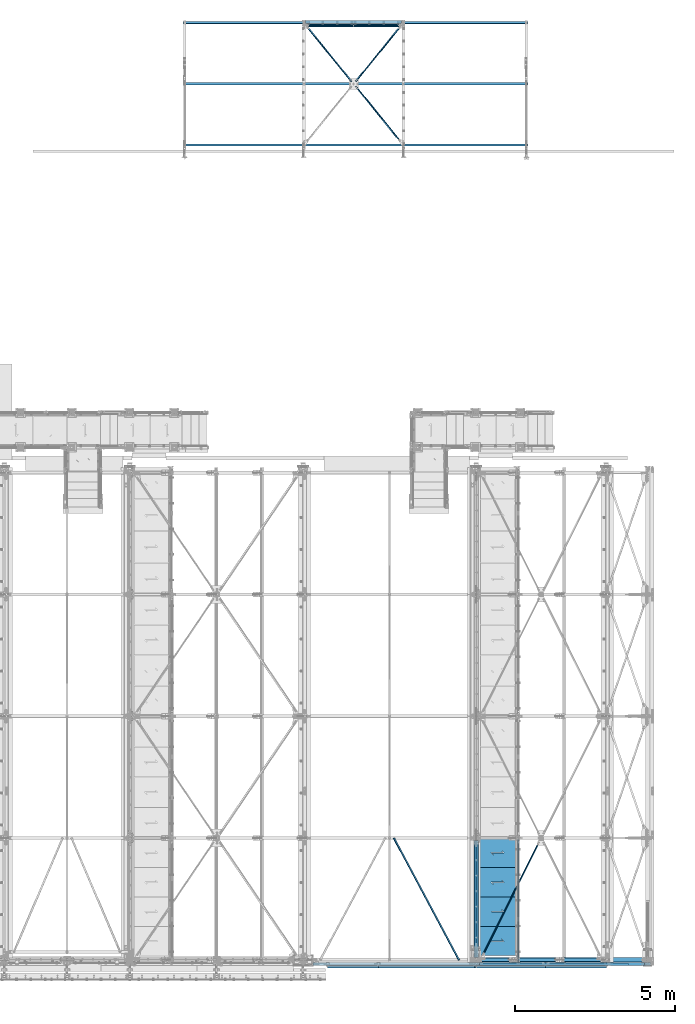
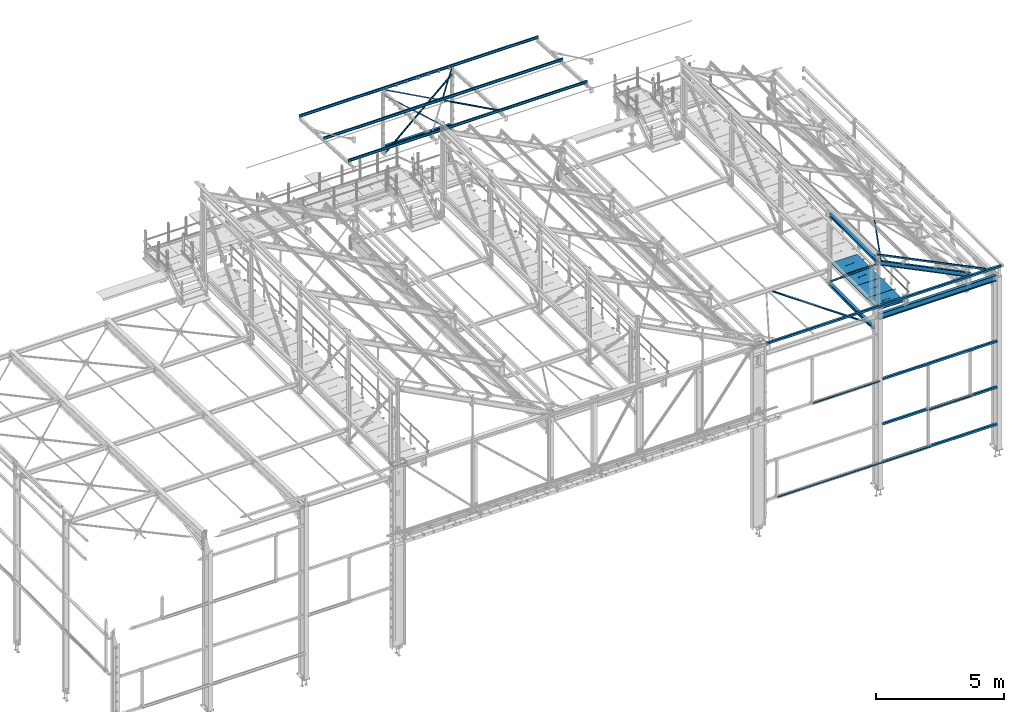
# One storey, part 54 of 496: 27 beams, 6 members, 31 elements without a shape of their own.
"""IFC2X3 building model written with IfcOpenShell, lengths in millimetres."""

from ifc_helpers import new_model, si_unit, frame, origin_with_axes, origin_2d_with_axis, place, context, subcontext, project, spatial, polyline, hollow_rectangle, hollow_circle, i_section, l_section, u_section, outline, extrude, boolean, clip, halfspace, material, type_object, element, aggregate, save


model = new_model("IFC2X3")

# Units and contexts
model_context = context("Model", 3, precision=1e-05, world=origin_with_axes())
body_context = subcontext(model_context, "Body", "Model", "MODEL_VIEW")
ifc_project = project(units=[si_unit("LENGTHUNIT", "METRE", prefix="MILLI"), si_unit("AREAUNIT", "SQUARE_METRE"), si_unit("VOLUMEUNIT", "CUBIC_METRE"), si_unit("MASSUNIT", "GRAM", prefix="KILO"), si_unit("TIMEUNIT", "SECOND"), si_unit("PLANEANGLEUNIT", "RADIAN"), si_unit("SOLIDANGLEUNIT", "STERADIAN"), si_unit("THERMODYNAMICTEMPERATUREUNIT", "DEGREE_CELSIUS"), si_unit("LUMINOUSINTENSITYUNIT", "LUMEN")], contexts=[model_context])

# Site, building, storey
site_placement = place(None, origin_with_axes())
site = spatial("IfcSite", under=ifc_project, at=site_placement, CompositionType="ELEMENT")
building_placement = place(site_placement, origin_with_axes())
building = spatial("IfcBuilding", under=site, at=building_placement, Name="Undefined", CompositionType="ELEMENT")
storey_placement = place(building_placement, origin_with_axes())
storey = spatial("IfcBuildingStorey", under=building, at=storey_placement, Name="Undefined", CompositionType="ELEMENT", Elevation=0.0)

# Assembly, beam
assembly_1_placement = place(storey_placement, origin_with_axes())
assembly_1 = element("IfcElementAssembly", 1, at=assembly_1_placement, inside=storey, AssemblyPlace="NOTDEFINED", PredefinedType="NOTDEFINED")
ifc_material_1 = material(Name="Undefined/S235-E24")
beam_type_1 = type_object("IfcBeamType", PredefinedType="NOTDEFINED")
beam_1_placement = place(assembly_1_placement, frame((33741.464794065, -6.80950368200683, 7825.10982356581), z_axis=(0.882450923754033, 0.470172348899255, -0.0147759769968343), x_axis=(-0.470404471881011, 0.882015474776895, -0.0277188579929885)))
beam_1 = element("IfcBeam", 2, at=beam_1_placement, type_object=beam_type_1, material=ifc_material_1, context=body_context, shape_type="SweptSolid", body=[
    extrude(l_section(Depth=50.0, Width=50.0, Thickness=5.0, FilletRadius=7.0, EdgeRadius=3.5, at=origin_2d_with_axis()), frame((4311.66025859928, -2.99181530841136e-14, 1.4211122714954e-13), z_axis=(-1.0, 0.0, 0.0), x_axis=(0.0, -1.0, 0.0)), (0.0, 0.0, 1.0), 4311.66),
])
aggregate(assembly_1, [beam_1])

assembly_2_placement = place(storey_placement, origin_with_axes())
assembly_2 = element("IfcElementAssembly", 3, at=assembly_2_placement, inside=storey, AssemblyPlace="NOTDEFINED", PredefinedType="NOTDEFINED")
beam_2_placement = place(assembly_2_placement, frame((36314.0683462876, 3801.21209552809, 9506.75815097872), z_axis=(0.784869567232957, -0.48483568373157, -0.385893926114537), x_axis=(-0.435090878201922, -0.874605259405945, 0.2139195360993)))
beam_2 = element("IfcBeam", 4, at=beam_2_placement, type_object=beam_type_1, material=ifc_material_1, context=body_context, shape_type="Clipping", body=[
    clip(clip(extrude(l_section(Depth=50.0, Width=50.0, Thickness=5.0, FilletRadius=7.0, EdgeRadius=3.5, at=origin_2d_with_axis()), frame((4262.41787878129, 0.0, 1.18305861739923e-13), z_axis=(-1.0, 0.0, 0.0), x_axis=(0.0, -1.0, 0.0)), (0.0, 0.0, 1.0), 4180.02), halfspace(frame((4208.92584894056, 24.9999461378866, 24.9999985431241), z_axis=(-1.0, 0.0, 0.0), x_axis=(0.0, -1.0, 0.0)), True)), halfspace(frame((135.890681967274, 24.9993722886538, -24.9999998762178), z_axis=(1.0, 0.0, 0.0), x_axis=(0.0, -1.0, 0.0)), True)),
])
aggregate(assembly_2, [beam_2])

assembly_3_placement = place(storey_placement, origin_with_axes())
assembly_3 = element("IfcElementAssembly", 5, at=assembly_3_placement, inside=storey, Name="LISSE", AssemblyPlace="NOTDEFINED", PredefinedType="NOTDEFINED")
beam_type_2 = type_object("IfcBeamType", PredefinedType="NOTDEFINED")
beam_3_placement = place(assembly_3_placement, frame((31952.9999389134, 29270.0000892359, 1465.0), z_axis=(0.0, 1.0, 0.0), x_axis=(-1.0, 0.0, 0.0)))
beam_3 = element("IfcBeam", 6, at=beam_3_placement, type_object=beam_type_2, material=ifc_material_1, Name="LISSE", context=body_context, shape_type="SweptSolid", body=[
    extrude(u_section(Depth=100.0, FlangeWidth=50.0, WebThickness=4.0, FlangeThickness=4.0, at=origin_2d_with_axis()), frame((2999.99999402831, 0.0, 0.0), z_axis=(-1.0, 0.0, 0.0), x_axis=(0.0, -1.0, 0.0)), (0.0, 0.0, 1.0), 3000.0),
])
aggregate(assembly_3, [beam_3])

assembly_4_placement = place(storey_placement, origin_with_axes())
assembly_4 = element("IfcElementAssembly", 7, at=assembly_4_placement, inside=storey, Name="LISSE", AssemblyPlace="NOTDEFINED", PredefinedType="NOTDEFINED")
beam_4_placement = place(assembly_4_placement, frame((31952.9999389134, 29270.0000892359, 124.999999999999), z_axis=(0.0, 1.0, 0.0), x_axis=(-1.0, 0.0, 0.0)))
beam_4 = element("IfcBeam", 8, at=beam_4_placement, type_object=beam_type_2, material=ifc_material_1, Name="LISSE", context=body_context, shape_type="SweptSolid", body=[
    extrude(u_section(Depth=100.0, FlangeWidth=50.0, WebThickness=4.0, FlangeThickness=4.0, at=origin_2d_with_axis()), frame((2999.99999402831, 0.0, 0.0), z_axis=(-1.0, 0.0, 0.0), x_axis=(0.0, -1.0, 0.0)), (0.0, 0.0, 1.0), 3000.0),
])
aggregate(assembly_4, [beam_4])

assembly_5_placement = place(storey_placement, origin_with_axes())
assembly_5 = element("IfcElementAssembly", 9, at=assembly_5_placement, inside=storey, Name="LISSE", AssemblyPlace="NOTDEFINED", PredefinedType="NOTDEFINED")
beam_type_3 = type_object("IfcBeamType", PredefinedType="NOTDEFINED")
beam_5_placement = place(assembly_5_placement, frame((36500.0025851056, -129.999792338778, 2810.00000034457), z_axis=(0.0, 0.0, -1.0), x_axis=(1.0, 0.0, 0.0)))
beam_5 = element("IfcBeam", 10, at=beam_5_placement, type_object=beam_type_3, material=ifc_material_1, Name="LISSE", context=body_context, shape_type="SweptSolid", body=[
    extrude(hollow_rectangle(XDim=100.0, YDim=100.0, WallThickness=4.0, InnerFilletRadius=4.0, OuterFilletRadius=8.0, at=origin_2d_with_axis()), frame((3024.99741454208, -2.82644087212594e-21, -4.54747350886464e-13), z_axis=(-1.0, 0.0, 0.0), x_axis=(0.0, -1.0, 0.0)), (0.0, 0.0, 1.0), 3025.0),
])

assembly_6_placement = place(storey_placement, origin_with_axes())
assembly_6 = element("IfcElementAssembly", 11, at=assembly_6_placement, inside=storey, Name="LISSE", AssemblyPlace="NOTDEFINED", PredefinedType="NOTDEFINED")
beam_6_placement = place(assembly_6_placement, frame((34384.9999999193, -129.999801565717, 4989.99996534904), z_axis=(0.0, 0.0, 1.0), x_axis=(1.0, 0.0, 0.0)))
beam_6 = element("IfcBeam", 12, at=beam_6_placement, type_object=beam_type_3, material=ifc_material_1, Name="LISSE", context=body_context, shape_type="SweptSolid", body=[
    extrude(hollow_rectangle(XDim=100.0, YDim=100.0, WallThickness=4.0, InnerFilletRadius=4.0, OuterFilletRadius=8.0, at=origin_2d_with_axis()), frame((5139.99999998194, -7.8549075754517e-22, 0.0), z_axis=(-1.0, 0.0, 0.0), x_axis=(0.0, -1.0, 0.0)), (0.0, 0.0, 1.0), 5140.0),
])
aggregate(assembly_6, [beam_6])

assembly_7_placement = place(storey_placement, origin_with_axes())
assembly_7 = element("IfcElementAssembly", 13, at=assembly_7_placement, inside=storey, Name="LISSE", AssemblyPlace="NOTDEFINED", PredefinedType="NOTDEFINED")
beam_7_placement = place(assembly_7_placement, frame((34384.9999991528, -129.999801565017, 2849.99996535), z_axis=(0.0, 0.0, -1.0), x_axis=(1.0, 0.0, 0.0)))
beam_7 = element("IfcBeam", 14, at=beam_7_placement, type_object=beam_type_3, material=ifc_material_1, Name="LISSE", context=body_context, shape_type="SweptSolid", body=[
    extrude(hollow_rectangle(XDim=100.0, YDim=100.0, WallThickness=4.0, InnerFilletRadius=4.0, OuterFilletRadius=8.0, at=origin_2d_with_axis()), frame((2005.00258543982, 5.68434172380363e-14, 0.0), z_axis=(-1.0, 0.0, 0.0), x_axis=(0.0, -1.0, 0.0)), (0.0, 0.0, 1.0), 2005.0),
])
aggregate(assembly_7, [beam_7])

assembly_8_placement = place(storey_placement, origin_with_axes())
assembly_8 = element("IfcElementAssembly", 15, at=assembly_8_placement, inside=storey, Name="LISSE", AssemblyPlace="NOTDEFINED", PredefinedType="NOTDEFINED")
beam_8_placement = place(assembly_8_placement, frame((34385.0000004793, -129.999801565642, 1049.99996534904), z_axis=(0.0, 0.0, 1.0), x_axis=(1.0, 0.0, 0.0)))
beam_8 = element("IfcBeam", 16, at=beam_8_placement, type_object=beam_type_3, material=ifc_material_1, Name="LISSE", context=body_context, shape_type="SweptSolid", body=[
    extrude(hollow_rectangle(XDim=100.0, YDim=100.0, WallThickness=4.0, InnerFilletRadius=4.0, OuterFilletRadius=8.0, at=origin_2d_with_axis()), frame((5139.99999998194, -7.8549075754517e-22, 0.0), z_axis=(-1.0, 0.0, 0.0), x_axis=(0.0, -1.0, 0.0)), (0.0, 0.0, 1.0), 5140.0),
])

assembly_9_placement = place(storey_placement, origin_with_axes())
assembly_9 = element("IfcElementAssembly", 17, at=assembly_9_placement, inside=storey, Name="LISSE", AssemblyPlace="NOTDEFINED", PredefinedType="NOTDEFINED")
beam_9_placement = place(assembly_9_placement, frame((29190.0, -130.0, 8500.0), z_axis=(0.0, 0.0, 1.0), x_axis=(1.0, 0.0, 0.0)))
beam_9 = element("IfcBeam", 18, at=beam_9_placement, type_object=beam_type_3, material=ifc_material_1, Name="LISSE", context=body_context, shape_type="SweptSolid", body=[
    extrude(hollow_rectangle(XDim=100.0, YDim=100.0, WallThickness=4.0, InnerFilletRadius=4.0, OuterFilletRadius=8.0, at=origin_2d_with_axis()), frame((10525.0, 0.0, 0.0), z_axis=(-1.0, 0.0, 0.0), x_axis=(0.0, -1.0, 0.0)), (0.0, 0.0, 1.0), 10525.0),
])
aggregate(assembly_9, [beam_9])

assembly_10_placement = place(storey_placement, origin_with_axes())
assembly_10 = element("IfcElementAssembly", 19, at=assembly_10_placement, inside=storey, AssemblyPlace="NOTDEFINED", PredefinedType="NOTDEFINED")
beam_type_4 = type_object("IfcBeamType", PredefinedType="NOTDEFINED")
beam_10_placement = place(assembly_10_placement, frame((30454.5529285372, 27335.0746863018, 2960.81333329999), z_axis=(-3.30331196424227e-10, 0.0523092382845414, 0.998630934625045), x_axis=(0.630132956270901, -0.775424193333384, 0.0406174570174624)))
beam_10 = element("IfcBeam", 20, at=beam_10_placement, type_object=beam_type_4, material=ifc_material_1, context=body_context, shape_type="Clipping", body=[
    clip(clip(extrude(l_section(Depth=40.0, Width=40.0, Thickness=4.0, FilletRadius=6.0, EdgeRadius=3.0, at=origin_2d_with_axis()), frame((2362.85080746814, -9.09494701772928e-13, -1.10316738496386e-12), z_axis=(-1.0, 0.0, 0.0), x_axis=(0.0, -1.0, 0.0)), (0.0, 0.0, 1.0), 2298.17), halfspace(frame((2320.08744489009, 19.9999999765496, -182.999998010003), z_axis=(-1.0, 0.0, 0.0), x_axis=(0.0, 0.0, 1.0)), True)), halfspace(frame((107.441569279686, 19.9999999472129, -182.999998012974), z_axis=(-1.0, 0.0, 0.0), x_axis=(0.0, 0.0, 1.0)), False)),
])
aggregate(assembly_10, [beam_10])

assembly_11_placement = place(storey_placement, origin_with_axes())
assembly_11 = element("IfcElementAssembly", 21, at=assembly_11_placement, inside=storey, AssemblyPlace="NOTDEFINED", PredefinedType="NOTDEFINED")
beam_11_placement = place(assembly_11_placement, frame((28901.4469646925, 29239.9446364429, 2861.03443346379), z_axis=(0.776487255157028, 0.629270263056629, -0.0329617750029666), x_axis=(0.630132956270901, -0.775424193333384, 0.0406174570174624)))
beam_11 = element("IfcBeam", 22, at=beam_11_placement, type_object=beam_type_4, material=ifc_material_1, context=body_context, shape_type="Clipping", body=[
    clip(clip(extrude(l_section(Depth=40.0, Width=40.0, Thickness=4.0, FilletRadius=6.0, EdgeRadius=3.0, at=origin_2d_with_axis()), frame((2393.69387448967, 0.0, 2.42396172445381e-13), z_axis=(-1.0, 0.0, 0.0), x_axis=(0.0, -1.0, 0.0)), (0.0, 0.0, 1.0), 2295.32), halfspace(frame((2352.35665650732, 182.999998764969, -20.0000000916625), z_axis=(1.0, 0.0, 0.0), x_axis=(0.0, -1.0, 0.0)), False)), halfspace(frame((139.710817372457, 182.999998767939, -20.0000001209846), z_axis=(1.0, 0.0, 0.0), x_axis=(0.0, -1.0, 0.0)), True)),
])
aggregate(assembly_11, [beam_11])

assembly_12_placement = place(storey_placement, origin_with_axes())
assembly_12 = element("IfcElementAssembly", 23, at=assembly_12_placement, inside=storey, AssemblyPlace="NOTDEFINED", PredefinedType="NOTDEFINED")
beam_12_placement = place(assembly_12_placement, frame((32004.5529154044, 29239.9446581708, 2861.03443352676), z_axis=(-3.30331196424227e-10, 0.0523092382845414, 0.998630934625045), x_axis=(-0.630132977867582, -0.775424175837016, 0.0406174559914615)))
beam_12 = element("IfcBeam", 24, at=beam_12_placement, type_object=beam_type_4, material=ifc_material_1, context=body_context, shape_type="Clipping", body=[
    clip(clip(extrude(l_section(Depth=40.0, Width=40.0, Thickness=4.0, FilletRadius=6.0, EdgeRadius=3.0, at=origin_2d_with_axis()), frame((2393.69387448967, 0.0, 2.42396172445381e-13), z_axis=(-1.0, 0.0, 0.0), x_axis=(0.0, -1.0, 0.0)), (0.0, 0.0, 1.0), 2295.32), halfspace(frame((2352.35665617366, 20.0000000572054, -182.999998859531), z_axis=(-1.0, 0.0, 0.0), x_axis=(0.0, 0.0, 1.0)), True)), halfspace(frame((139.710821488145, 20.0000000865521, -182.999999904179), z_axis=(-1.0, 0.0, 0.0), x_axis=(0.0, 0.0, 1.0)), False)),
])
aggregate(assembly_12, [beam_12])

assembly_13_placement = place(storey_placement, origin_with_axes())
assembly_13 = element("IfcElementAssembly", 25, at=assembly_13_placement, inside=storey, AssemblyPlace="NOTDEFINED", PredefinedType="NOTDEFINED")
beam_type_5 = type_object("IfcBeamType", PredefinedType="NOTDEFINED")
beam_13_placement = place(assembly_13_placement, frame((35536.4916120059, 1035.00033833364, 8115.0), z_axis=(0.0, 0.0, 1.0), x_axis=(-1.0, 0.0, 0.0)))
beam_13 = element("IfcBeam", 26, at=beam_13_placement, type_object=beam_type_5, material=ifc_material_1, context=body_context, shape_type="CSG", body=[
    boolean("DIFFERENCE", boolean("DIFFERENCE", extrude(outline(polyline([(0.0, 0.0), (1179.99169921875, 0.0), (1179.99169921875, 910.0), (-9.39995516091585e-07, 910.0), (0.0, 0.0)])), frame((0.0, 0.0, -15.0), z_axis=(0.0, 0.0, 1.0), x_axis=(1.0, 0.0, 0.0)), (0.0, 0.0, 1.0), 30.0), extrude(outline(polyline([(0.0, 0.0), (33.4972381591797, 0.0), (33.4972381591797, 204.999664306641), (0.0, 204.999664306641), (0.0, 0.0)])), frame((1179.99169921875, 705.000337675051, 17.5), z_axis=(0.0, 0.0, -1.0), x_axis=(-1.0, 0.0, 0.0)), (0.0, 0.0, 1.0), 35.0)), extrude(outline(polyline([(0.0, 0.0), (9.99999999997453, 6.91215973347425e-11), (10.0000000004329, 75.8578643791443), (282.842712400121, -196.984848017997), (282.842712400743, -96.9848480190813), (272.842712400776, -96.9848480191613), (272.842712400299, -172.842712398218), (0.0, 100.0), (0.0, 0.0)])), frame((724.285170968404, 520.710678119967, -17.5), z_axis=(0.0, 0.0, 1.0), x_axis=(-0.707106781186457, -0.707106781186639, 0.0)), (0.0, 0.0, 1.0), 35.0)),
])
aggregate(assembly_13, [beam_13])

assembly_14_placement = place(storey_placement, origin_with_axes())
assembly_14 = element("IfcElementAssembly", 27, at=assembly_14_placement, inside=storey, AssemblyPlace="NOTDEFINED", PredefinedType="NOTDEFINED")
beam_14_placement = place(assembly_14_placement, frame((35536.4916120059, 1955.00033356438, 8115.0), z_axis=(0.0, 0.0, 1.0), x_axis=(-1.0, 0.0, 0.0)))
beam_14 = element("IfcBeam", 28, at=beam_14_placement, type_object=beam_type_5, material=ifc_material_1, context=body_context, shape_type="CSG", body=[
    boolean("DIFFERENCE", extrude(outline(polyline([(0.0, 0.0), (1179.99169921875, 0.0), (1179.99169921875, 910.0), (-9.39995516091585e-07, 910.0), (0.0, 0.0)])), frame((0.0, 0.0, -15.0), z_axis=(0.0, 0.0, 1.0), x_axis=(1.0, 0.0, 0.0)), (0.0, 0.0, 1.0), 30.0), extrude(outline(polyline([(0.0, 0.0), (9.99999999997453, 6.91215973347425e-11), (10.0000000004329, 75.8578643791443), (282.842712400121, -196.984848017997), (282.842712400743, -96.9848480190813), (272.842712400776, -96.9848480191613), (272.842712400299, -172.842712398218), (0.0, 100.0), (0.0, 0.0)])), frame((724.285170968404, 520.710678119967, -17.5), z_axis=(0.0, 0.0, 1.0), x_axis=(-0.707106781186457, -0.707106781186639, 0.0)), (0.0, 0.0, 1.0), 35.0)),
])
aggregate(assembly_14, [beam_14])

assembly_15_placement = place(storey_placement, origin_with_axes())
assembly_15 = element("IfcElementAssembly", 29, at=assembly_15_placement, inside=storey, AssemblyPlace="NOTDEFINED", PredefinedType="NOTDEFINED")
beam_15_placement = place(assembly_15_placement, frame((35536.4916120059, 2875.00032879511, 8115.0), z_axis=(0.0, 0.0, 1.0), x_axis=(-1.0, 0.0, 0.0)))
beam_15 = element("IfcBeam", 30, at=beam_15_placement, type_object=beam_type_5, material=ifc_material_1, context=body_context, shape_type="CSG", body=[
    boolean("DIFFERENCE", extrude(outline(polyline([(0.0, 0.0), (1179.99169921875, 0.0), (1179.99169921875, 910.0), (-9.39995516091585e-07, 910.0), (0.0, 0.0)])), frame((0.0, 0.0, -15.0), z_axis=(0.0, 0.0, 1.0), x_axis=(1.0, 0.0, 0.0)), (0.0, 0.0, 1.0), 30.0), extrude(outline(polyline([(0.0, 0.0), (9.99999999997453, 6.91215973347425e-11), (10.0000000004329, 75.8578643791443), (282.842712400121, -196.984848017997), (282.842712400743, -96.9848480190813), (272.842712400776, -96.9848480191613), (272.842712400299, -172.842712398218), (0.0, 100.0), (0.0, 0.0)])), frame((724.285170968404, 520.710678119967, -17.5), z_axis=(0.0, 0.0, 1.0), x_axis=(-0.707106781186457, -0.707106781186639, 0.0)), (0.0, 0.0, 1.0), 35.0)),
])
aggregate(assembly_15, [beam_15])

assembly_16_placement = place(storey_placement, origin_with_axes())
assembly_16 = element("IfcElementAssembly", 31, at=assembly_16_placement, inside=storey, AssemblyPlace="NOTDEFINED", PredefinedType="NOTDEFINED")
beam_16_placement = place(assembly_16_placement, frame((35536.4916120059, 3795.00032402585, 8115.0), z_axis=(0.0, 0.0, 1.0), x_axis=(-1.0, 0.0, 0.0)))
beam_16 = element("IfcBeam", 32, at=beam_16_placement, type_object=beam_type_5, material=ifc_material_1, context=body_context, shape_type="CSG", body=[
    boolean("DIFFERENCE", extrude(outline(polyline([(0.0, 0.0), (1179.99169921875, 0.0), (1179.99169921875, 910.0), (-9.39995516091585e-07, 910.0), (0.0, 0.0)])), frame((0.0, 0.0, -15.0), z_axis=(0.0, 0.0, 1.0), x_axis=(1.0, 0.0, 0.0)), (0.0, 0.0, 1.0), 30.0), extrude(outline(polyline([(0.0, 0.0), (9.99999999997453, 6.91215973347425e-11), (10.0000000004329, 75.8578643791443), (282.842712400121, -196.984848017997), (282.842712400743, -96.9848480190813), (272.842712400776, -96.9848480191613), (272.842712400299, -172.842712398218), (0.0, 100.0), (0.0, 0.0)])), frame((724.285170968404, 520.710678119967, -17.5), z_axis=(0.0, 0.0, 1.0), x_axis=(-0.707106781186457, -0.707106781186639, 0.0)), (0.0, 0.0, 1.0), 35.0)),
])
aggregate(assembly_16, [beam_16])

# Beam
beam_type_6 = type_object("IfcBeamType", PredefinedType="NOTDEFINED")
beam_17_placement = place(assembly_8_placement, frame((34290.0, -215.000007684151, 1065.0), z_axis=(0.0, -1.0, 0.0), x_axis=(1.0, 0.0, 0.0)))
beam_17 = element("IfcBeam", 33, at=beam_17_placement, type_object=beam_type_6, material=ifc_material_1, Name="SUPPORT", context=body_context, shape_type="SweptSolid", body=[
    extrude(l_section(Depth=70.0, Width=70.0, Thickness=7.0, FilletRadius=9.0, EdgeRadius=4.5, at=origin_2d_with_axis()), frame((2154.99781573291, 0.0, 0.0), z_axis=(-1.0, 0.0, 0.0), x_axis=(0.0, -1.0, 0.0)), (0.0, 0.0, 1.0), 2155.0),
])

aggregate(assembly_8, [beam_17, beam_8])

beam_18_placement = place(assembly_5_placement, frame((36445.0025836993, -215.000007684151, 2825.0), z_axis=(0.0, -1.0, 0.0), x_axis=(1.0, 0.0, 0.0)))
beam_18 = element("IfcBeam", 34, at=beam_18_placement, type_object=beam_type_6, material=ifc_material_1, Name="SUPPORT", context=body_context, shape_type="SweptSolid", body=[
    extrude(l_section(Depth=70.0, Width=70.0, Thickness=7.0, FilletRadius=9.0, EdgeRadius=4.5, at=origin_2d_with_axis()), frame((1899.99781571392, 0.0, 0.0), z_axis=(-1.0, 0.0, 0.0), x_axis=(0.0, -1.0, 0.0)), (0.0, 0.0, 1.0), 1900.0),
])

aggregate(assembly_5, [beam_5, beam_18])

# Assembly, beam
assembly_17_placement = place(storey_placement, origin_with_axes())
assembly_17 = element("IfcElementAssembly", 35, at=assembly_17_placement, inside=storey, Name="LISSE", AssemblyPlace="NOTDEFINED", PredefinedType="NOTDEFINED")
beam_19_placement = place(assembly_17_placement, frame((29645.000000019, -215.000007684151, 1065.0), z_axis=(0.0, -1.0, 0.0), x_axis=(1.0, 0.0, 0.0)))
beam_19 = element("IfcBeam", 36, at=beam_19_placement, type_object=beam_type_6, material=ifc_material_1, Name="SUPPORT", context=body_context, shape_type="SweptSolid", body=[
    extrude(l_section(Depth=70.0, Width=70.0, Thickness=7.0, FilletRadius=9.0, EdgeRadius=4.5, at=origin_2d_with_axis()), frame((4624.99999998101, 0.0, 0.0), z_axis=(-1.0, 0.0, 0.0), x_axis=(0.0, -1.0, 0.0)), (0.0, 0.0, 1.0), 4625.0),
])
aggregate(assembly_17, [beam_19])

assembly_18_placement = place(storey_placement, origin_with_axes())
assembly_18 = element("IfcElementAssembly", 37, at=assembly_18_placement, inside=storey, Name="LISSE", AssemblyPlace="NOTDEFINED", PredefinedType="NOTDEFINED")
beam_20_placement = place(assembly_18_placement, frame((31230.000000019, -215.000007684151, 4965.0), z_axis=(0.0, -1.0, 0.0), x_axis=(1.0, 0.0, 0.0)))
beam_20 = element("IfcBeam", 38, at=beam_20_placement, type_object=beam_type_6, material=ifc_material_1, Name="SUPPORT", context=body_context, shape_type="SweptSolid", body=[
    extrude(l_section(Depth=70.0, Width=70.0, Thickness=7.0, FilletRadius=9.0, EdgeRadius=4.5, at=origin_2d_with_axis()), frame((2999.99781571392, 0.0, 0.0), z_axis=(-1.0, 0.0, 0.0), x_axis=(0.0, -1.0, 0.0)), (0.0, 0.0, 1.0), 3000.0),
])
aggregate(assembly_18, [beam_20])

assembly_19_placement = place(storey_placement, origin_with_axes())
assembly_19 = element("IfcElementAssembly", 39, at=assembly_19_placement, inside=storey, Name="MAIN COURANTE", AssemblyPlace="NOTDEFINED", PredefinedType="NOTDEFINED")
beam_type_7 = type_object("IfcBeamType", PredefinedType="NOTDEFINED")
beam_21_placement = place(assembly_19_placement, frame((35593.9917143587, 3744.99999422552, 8673.80000478163), z_axis=(0.0, 0.0, 1.0), x_axis=(0.0, -1.0, 0.0)))
beam_21 = element("IfcBeam", 40, at=beam_21_placement, type_object=beam_type_7, material=ifc_material_1, Name="LISSE", context=body_context, shape_type="SweptSolid", body=[
    extrude(hollow_circle(Radius=13.44999981, WallThickness=2.0, at=origin_2d_with_axis()), frame((3845.00000000169, 3.84500099235122e-24, 0.0), z_axis=(-1.0, 0.0, 0.0), x_axis=(0.0, -1.0, 0.0)), (0.0, 0.0, 1.0), 3845.0),
])
aggregate(assembly_19, [beam_21])

assembly_20_placement = place(storey_placement, origin_with_axes())
assembly_20 = element("IfcElementAssembly", 41, at=assembly_20_placement, inside=storey, AssemblyPlace="NOTDEFINED", PredefinedType="NOTDEFINED")
ifc_material_2 = material(Name="Undefined/S275-E28")
beam_type_8 = type_object("IfcBeamType", Name="HEA140", PredefinedType="NOTDEFINED")
beam_22_placement = place(assembly_20_placement, frame((34279.9999999422, 3795.00000000052, 7183.50000000039), z_axis=(0.0, 0.0, 1.0), x_axis=(0.0, -1.0, 0.0)))
beam_22 = element("IfcBeam", 42, at=beam_22_placement, type_object=beam_type_8, material=ifc_material_2, ObjectType="HEA140", context=body_context, shape_type="SweptSolid", body=[
    extrude(i_section(OverallWidth=140.0, OverallDepth=133.0, WebThickness=5.5, FlangeThickness=8.5, FilletRadius=12.0, at=origin_2d_with_axis()), frame((3465.00016060513, 0.0, 0.0), z_axis=(-1.0, 0.0, 0.0), x_axis=(0.0, -1.0, 0.0)), (0.0, 0.0, 1.0), 3465.0),
])
aggregate(assembly_20, [beam_22])

assembly_21_placement = place(storey_placement, origin_with_axes())
assembly_21 = element("IfcElementAssembly", 43, at=assembly_21_placement, inside=storey, AssemblyPlace="NOTDEFINED", PredefinedType="NOTDEFINED")
beam_23_placement = place(assembly_21_placement, frame((34283.5, 3725.0, 10489.5), z_axis=(0.0, 0.0, 1.0), x_axis=(0.0, -1.0, 0.0)))
beam_23 = element("IfcBeam", 44, at=beam_23_placement, type_object=beam_type_8, material=ifc_material_2, ObjectType="HEA140", context=body_context, shape_type="SweptSolid", body=[
    extrude(i_section(OverallWidth=140.0, OverallDepth=133.0, WebThickness=5.5, FlangeThickness=8.5, FilletRadius=12.0, at=origin_2d_with_axis()), frame((3650.0, 0.0, 0.0), z_axis=(-1.0, 0.0, 0.0), x_axis=(0.0, -1.0, 0.0)), (0.0, 0.0, 1.0), 3650.0),
])
aggregate(assembly_21, [beam_23])

# Assembly, member
assembly_22_placement = place(storey_placement, origin_with_axes())
assembly_22 = element("IfcElementAssembly", 45, at=assembly_22_placement, inside=storey, AssemblyPlace="NOTDEFINED", PredefinedType="NOTDEFINED")
member_type_1 = type_object("IfcMemberType", PredefinedType="NOTDEFINED")
member_1_placement = place(assembly_22_placement, frame((28901.6659183142, 29180.0000662499, 2623.50982973513), z_axis=(0.0, 1.0, 0.0), x_axis=(0.745084152912126, 0.0, -0.666970467921347)))
member_1 = element("IfcMember", 46, at=member_1_placement, type_object=member_type_1, material=ifc_material_1, context=body_context, shape_type="Clipping", body=[
    clip(clip(extrude(l_section(Depth=40.0, Width=40.0, Thickness=4.0, FilletRadius=6.0, EdgeRadius=3.0, at=origin_2d_with_axis()), frame((4160.60400395333, 0.0, -7.27595761590421e-12), z_axis=(-1.0, 0.0, 0.0), x_axis=(0.0, -1.0, 0.0)), (0.0, 0.0, 1.0), 4160.6), halfspace(frame((4072.67344886242, -20.0, -20.0000000000036), z_axis=(1.0, 0.0, 0.0), x_axis=(0.0, 0.0, 1.0)), False)), halfspace(frame((87.9306736696599, 20.0, -20.0000000000073), z_axis=(-1.0, 0.0, 0.0), x_axis=(0.0, 0.0, 1.0)), False)),
])
aggregate(assembly_22, [member_1])

assembly_23_placement = place(storey_placement, origin_with_axes())
assembly_23 = element("IfcElementAssembly", 47, at=assembly_23_placement, inside=storey, AssemblyPlace="NOTDEFINED", PredefinedType="NOTDEFINED")
member_2_placement = place(assembly_23_placement, frame((28904.3339113574, 29135.0000662499, -151.490168333243), z_axis=(-0.666970494282031, 0.0, 0.745084129315061), x_axis=(0.745084129315062, 0.0, 0.66697049428203)))
member_2 = element("IfcMember", 48, at=member_2_placement, type_object=member_type_1, material=ifc_material_1, context=body_context, shape_type="Clipping", body=[
    clip(clip(extrude(l_section(Depth=40.0, Width=40.0, Thickness=4.0, FilletRadius=6.0, EdgeRadius=3.0, at=origin_2d_with_axis()), frame((4160.60383853128, -1.72078541587339e-21, -2.30959908894061e-13), z_axis=(-1.0, 0.0, 0.0), x_axis=(0.0, -1.0, 0.0)), (0.0, 0.0, 1.0), 4160.6), halfspace(frame((87.9305276985906, 20.0, -20.0), z_axis=(-1.0, 0.0, 0.0), x_axis=(0.0, 0.0, 1.0)), False)), halfspace(frame((4072.67337888854, -20.0, -20.0), z_axis=(1.0, 0.0, 0.0), x_axis=(0.0, 0.0, 1.0)), False)),
])
aggregate(assembly_23, [member_2])

assembly_24_placement = place(storey_placement, origin_with_axes())
assembly_24 = element("IfcElementAssembly", 49, at=assembly_24_placement, inside=storey, AssemblyPlace="NOTDEFINED", PredefinedType="NOTDEFINED")
member_type_2 = type_object("IfcMemberType", PredefinedType="NOTDEFINED")
member_3_placement = place(assembly_24_placement, frame((34119.0787216377, -144.999999892429, 11006.064600962), z_axis=(-0.441220935974661, 0.0, -0.89739850994842), x_axis=(0.897398510539058, 0.0, -0.441220934773362)))
member_3 = element("IfcMember", 50, at=member_3_placement, type_object=member_type_2, material=ifc_material_1, context=body_context, shape_type="SweptSolid", body=[
    extrude(l_section(Depth=70.0, Width=70.0, Thickness=7.0, FilletRadius=9.0, EdgeRadius=4.5, at=origin_2d_with_axis()), frame((5450.00354320655, 0.0, -3.0253597089783e-13), z_axis=(-1.0, 0.0, 0.0), x_axis=(0.0, -1.0, 0.0)), (0.0, 0.0, 1.0), 5450.0),
])
aggregate(assembly_24, [member_3])

assembly_25_placement = place(storey_placement, origin_with_axes())
assembly_25 = element("IfcElementAssembly", 51, at=assembly_25_placement, inside=storey, AssemblyPlace="NOTDEFINED", PredefinedType="NOTDEFINED")
member_type_3 = type_object("IfcMemberType", Name="UPN80", PredefinedType="NOTDEFINED")
member_4_placement = place(assembly_25_placement, frame((34307.5000000055, 3799.99999999888, 7250.0), z_axis=(0.0, -0.640939616064268, -0.767591303076962), x_axis=(0.0, -0.767591727593998, 0.640939107660986)))
member_4 = element("IfcMember", 52, at=member_4_placement, type_object=member_type_3, material=ifc_material_2, ObjectType="UPN80", context=body_context, shape_type="Clipping", body=[
    clip(clip(extrude(u_section(Depth=80.0, FlangeWidth=45.0, WebThickness=6.0, FlangeThickness=8.0, FilletRadius=8.0, EdgeRadius=4.0, FlangeSlope=0.0798299857122373, at=origin_2d_with_axis()), frame((4910.04802976503, 0.0, -5.45124837466052e-13), z_axis=(-1.0, 0.0, 0.0), x_axis=(0.0, -1.0, 0.0)), (0.0, 0.0, 1.0), 4869.55), halfspace(frame((4830.54411414156, 27.5000000054715, -39.9999989979842), z_axis=(-1.0, 0.0, 0.0), x_axis=(0.0, 1.0, 0.0)), True)), halfspace(frame((119.999999997919, 27.49999999375, -39.9999989691296), z_axis=(-1.0, 0.0, 0.0), x_axis=(0.0, 1.0, 0.0)), False)),
])
aggregate(assembly_25, [member_4])

assembly_26_placement = place(storey_placement, origin_with_axes())
assembly_26 = element("IfcElementAssembly", 53, at=assembly_26_placement, inside=storey, AssemblyPlace="NOTDEFINED", PredefinedType="NOTDEFINED")
member_5_placement = place(assembly_26_placement, frame((34252.4999999925, 0.00552265711644395, 10422.9999997217), z_axis=(0.0, -0.640939616064268, -0.767591303076962), x_axis=(0.0, 0.767591303076962, -0.640939616064268)))
member_5 = element("IfcMember", 54, at=member_5_placement, type_object=member_type_3, material=ifc_material_2, ObjectType="UPN80", context=body_context, shape_type="Clipping", body=[
    clip(clip(extrude(u_section(Depth=80.0, FlangeWidth=45.0, WebThickness=6.0, FlangeThickness=8.0, FilletRadius=8.0, EdgeRadius=4.0, FlangeSlope=0.0798299857122373, at=origin_2d_with_axis()), frame((4910.04802976503, 0.0, -5.45124837466052e-13), z_axis=(-1.0, 0.0, 0.0), x_axis=(0.0, -1.0, 0.0)), (0.0, 0.0, 1.0), 4869.55), halfspace(frame((4830.54411414156, 27.5000000054715, -39.9999989979842), z_axis=(1.0, 0.0, 0.0), x_axis=(0.0, -1.0, 0.0)), False)), halfspace(frame((119.999999997919, 27.49999999375, -39.9999989691296), z_axis=(1.0, 0.0, 0.0), x_axis=(0.0, -1.0, 0.0)), True)),
])
aggregate(assembly_26, [member_5])

# Assembly, beam
assembly_27_placement = place(storey_placement, origin_with_axes())
assembly_27 = element("IfcElementAssembly", 55, at=assembly_27_placement, inside=storey, AssemblyPlace="NOTDEFINED", PredefinedType="NOTDEFINED")
beam_type_9 = type_object("IfcBeamType", Name="IPE120", PredefinedType="NOTDEFINED")
beam_24_placement = place(assembly_27_placement, frame((25134.9999687937, 25428.3645350491, 3097.73934976284), z_axis=(-3.30331196424227e-10, 0.0523092382845414, 0.998630934625045), x_axis=(1.0, 0.0, 0.0)))
beam_24 = element("IfcBeam", 56, at=beam_24_placement, type_object=beam_type_9, material=ifc_material_2, ObjectType="IPE120", context=body_context, shape_type="SweptSolid", body=[
    extrude(i_section(OverallWidth=64.0, OverallDepth=120.0, WebThickness=4.400000095, FlangeThickness=6.300000191, FilletRadius=7.0, at=origin_2d_with_axis()), frame((10758.0000000001, -1.7797618059691e-20, -1.11235112873069e-21), z_axis=(-1.0, 0.0, 0.0), x_axis=(0.0, -1.0, 0.0)), (0.0, 0.0, 1.0), 10758.0),
])
aggregate(assembly_27, [beam_24])

assembly_28_placement = place(storey_placement, origin_with_axes())
assembly_28 = element("IfcElementAssembly", 57, at=assembly_28_placement, inside=storey, AssemblyPlace="NOTDEFINED", PredefinedType="NOTDEFINED")
beam_25_placement = place(assembly_28_placement, frame((25134.9999539071, 27335.7515630884, 2997.82860208715), z_axis=(-3.30331196424227e-10, 0.0523092382845414, 0.998630934625045), x_axis=(1.0, 0.0, 0.0)))
beam_25 = element("IfcBeam", 58, at=beam_25_placement, type_object=beam_type_9, material=ifc_material_2, ObjectType="IPE120", context=body_context, shape_type="SweptSolid", body=[
    extrude(i_section(OverallWidth=64.0, OverallDepth=120.0, WebThickness=4.400000095, FlangeThickness=6.300000191, FilletRadius=7.0, at=origin_2d_with_axis()), frame((10758.0000000001, -1.7797618059691e-20, -1.11235112873069e-21), z_axis=(-1.0, 0.0, 0.0), x_axis=(0.0, -1.0, 0.0)), (0.0, 0.0, 1.0), 10758.0),
])
aggregate(assembly_28, [beam_25])

assembly_29_placement = place(storey_placement, origin_with_axes())
assembly_29 = element("IfcElementAssembly", 59, at=assembly_29_placement, inside=storey, AssemblyPlace="NOTDEFINED", PredefinedType="NOTDEFINED")
beam_26_placement = place(assembly_29_placement, frame((25134.9999390204, 29243.1385911278, 2897.91785441146), z_axis=(-3.30331196424227e-10, 0.0523092382845414, 0.998630934625045), x_axis=(1.0, 0.0, 0.0)))
beam_26 = element("IfcBeam", 60, at=beam_26_placement, type_object=beam_type_9, material=ifc_material_2, ObjectType="IPE120", context=body_context, shape_type="SweptSolid", body=[
    extrude(i_section(OverallWidth=64.0, OverallDepth=120.0, WebThickness=4.400000095, FlangeThickness=6.300000191, FilletRadius=7.0, at=origin_2d_with_axis()), frame((10758.0000000001, -1.7797618059691e-20, -1.11235112873069e-21), z_axis=(-1.0, 0.0, 0.0), x_axis=(0.0, -1.0, 0.0)), (0.0, 0.0, 1.0), 10758.0),
])
aggregate(assembly_29, [beam_26])

assembly_30_placement = place(storey_placement, origin_with_axes())
assembly_30 = element("IfcElementAssembly", 61, at=assembly_30_placement, inside=storey, AssemblyPlace="NOTDEFINED", PredefinedType="NOTDEFINED")
beam_type_10 = type_object("IfcBeamType", Name="IPE270", PredefinedType="NOTDEFINED")
beam_27_placement = place(assembly_30_placement, frame((34295.0, -1.09937804926677, 7914.9697753856), z_axis=(0.0, 0.031410887010906, 0.999506556345274), x_axis=(1.0, 0.0, 0.0)))
beam_27 = element("IfcBeam", 62, at=beam_27_placement, type_object=beam_type_10, material=ifc_material_2, ObjectType="IPE270", context=body_context, shape_type="SweptSolid", body=[
    extrude(i_section(OverallWidth=135.0, OverallDepth=270.0, WebThickness=6.599999905, FlangeThickness=10.19999981, FilletRadius=15.0, at=origin_2d_with_axis()), frame((5260.00000000002, 0.0, 0.0), z_axis=(-1.0, 0.0, 0.0), x_axis=(0.0, -1.0, 0.0)), (0.0, 0.0, 1.0), 5260.0),
])
aggregate(assembly_30, [beam_27])

# Assembly, member
assembly_31_placement = place(storey_placement, origin_with_axes())
assembly_31 = element("IfcElementAssembly", 63, at=assembly_31_placement, inside=storey, Name="TRAVERSE SHED", AssemblyPlace="NOTDEFINED", PredefinedType="NOTDEFINED")
member_type_4 = type_object("IfcMemberType", Name="IPE200", PredefinedType="NOTDEFINED")
member_6_placement = place(assembly_31_placement, frame((34305.8779065378, -3.19837843542485e-09, 10466.2601489394), z_axis=(0.441221071222121, 0.0, 0.897398443451739), x_axis=(0.897398510539058, 0.0, -0.441220934773362)))
member_6 = element("IfcMember", 64, at=member_6_placement, type_object=member_type_4, material=ifc_material_2, Name="TRAVERSE SHED", ObjectType="IPE200", context=body_context, shape_type="Clipping", body=[
    clip(clip(extrude(i_section(OverallWidth=100.0, OverallDepth=200.0, WebThickness=5.599999905, FlangeThickness=8.5, FilletRadius=12.0, at=origin_2d_with_axis()), frame((4652.25219148987, 0.0, 0.0), z_axis=(-1.0, 0.0, 0.0), x_axis=(0.0, -1.0, 0.0)), (0.0, 0.0, 1.0), 4763.89), halfspace(frame((4421.9420250161, 3.19837843542485e-09, -100.0), z_axis=(0.848887783899296, 0.0, -0.528573107854099), x_axis=(0.0, -1.0, 0.0)), False)), halfspace(frame((5.83309030194869, 3.19837843542485e-09, 102.867936075316), z_axis=(-0.89739851053906, 0.0, -0.44122093477336), x_axis=(0.0, -1.0, 0.0)), False)),
])
aggregate(assembly_31, [member_6])

save(model, "model.ifc")
